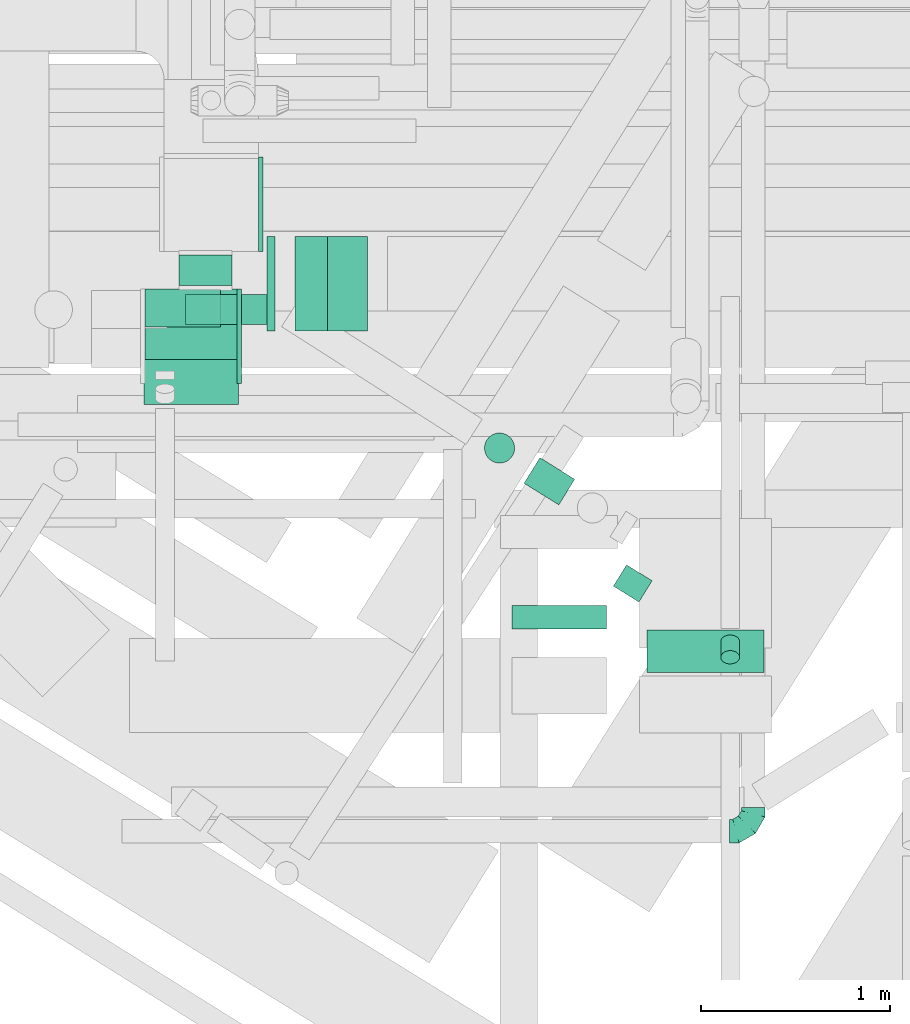
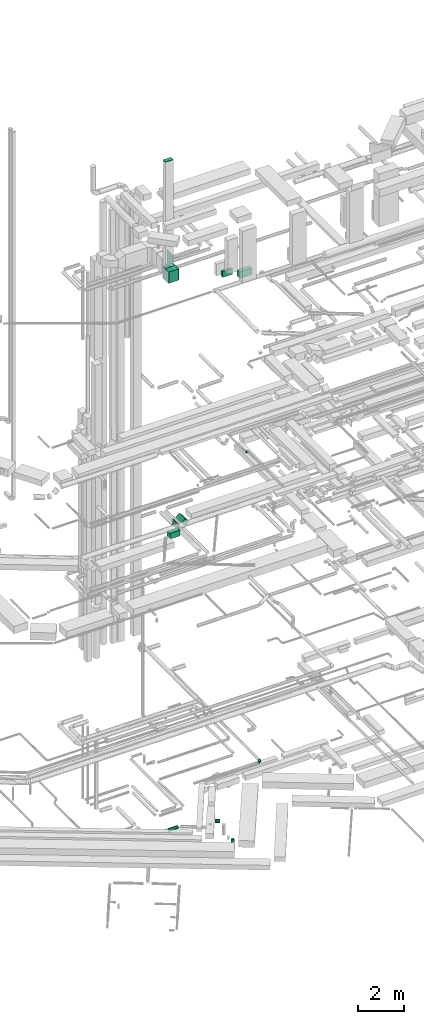
# One storey, part 95 of 337: 12 flow segments, 5 flow fittings.
"""IFC2X3 building model written with IfcOpenShell, lengths in millimetres."""

from ifc_helpers import new_model, entity, si_unit, converted_unit, derived_unit, direction, frame, frame_2d, origin, origin_2d_with_axis, place, context, subcontext, project, spatial, rectangle, circle, extrude, faceted_brep, source, transform, mapped, material, type_object, type_shapes, element, save


model = new_model("IFC2X3")

# Units and contexts
model_context = context("Model", 3, precision=0.01, world=origin(), true_north=direction((6.12303176911189e-17, 1.0)))
body_context = subcontext(model_context, "Body", "Model", "MODEL_VIEW")
ifc_project = project(units=[si_unit("LENGTHUNIT", "METRE", prefix="MILLI"), si_unit("AREAUNIT", "SQUARE_METRE"), si_unit("VOLUMEUNIT", "CUBIC_METRE"), converted_unit("PLANEANGLEUNIT", "DEGREE", entity("IfcRatioMeasure", 0.0174532925199433), si_unit("PLANEANGLEUNIT", "RADIAN"), dimensions=[0, 0, 0, 0, 0, 0, 0]), si_unit("MASSUNIT", "GRAM", prefix="KILO"), derived_unit("MASSDENSITYUNIT", [(si_unit("MASSUNIT", "GRAM", prefix="KILO"), 1), (si_unit("LENGTHUNIT", "METRE"), -3)]), derived_unit("MOMENTOFINERTIAUNIT", [(si_unit("LENGTHUNIT", "METRE"), 4)]), si_unit("TIMEUNIT", "SECOND"), si_unit("FREQUENCYUNIT", "HERTZ"), si_unit("THERMODYNAMICTEMPERATUREUNIT", "DEGREE_CELSIUS"), derived_unit("THERMALTRANSMITTANCEUNIT", [(si_unit("MASSUNIT", "GRAM", prefix="KILO"), 1), (si_unit("THERMODYNAMICTEMPERATUREUNIT", "KELVIN"), -1), (si_unit("TIMEUNIT", "SECOND"), -3)]), derived_unit("VOLUMETRICFLOWRATEUNIT", [(si_unit("LENGTHUNIT", "METRE"), 3), (si_unit("TIMEUNIT", "SECOND"), -1)]), derived_unit("MASSFLOWRATEUNIT", [(si_unit("MASSUNIT", "GRAM", prefix="KILO"), 1), (si_unit("TIMEUNIT", "SECOND"), -1)]), derived_unit("ROTATIONALFREQUENCYUNIT", [(si_unit("TIMEUNIT", "SECOND"), -1)]), si_unit("ELECTRICCURRENTUNIT", "AMPERE"), si_unit("ELECTRICVOLTAGEUNIT", "VOLT"), si_unit("POWERUNIT", "WATT"), si_unit("FORCEUNIT", "NEWTON", prefix="KILO"), si_unit("ILLUMINANCEUNIT", "LUX"), si_unit("LUMINOUSFLUXUNIT", "LUMEN"), si_unit("LUMINOUSINTENSITYUNIT", "CANDELA"), derived_unit("USERDEFINED", [(si_unit("MASSUNIT", "GRAM", prefix="KILO"), -1), (si_unit("LENGTHUNIT", "METRE"), -2), (si_unit("TIMEUNIT", "SECOND"), 3), (si_unit("LUMINOUSFLUXUNIT", "LUMEN"), 1)]), derived_unit("LINEARVELOCITYUNIT", [(si_unit("LENGTHUNIT", "METRE"), 1), (si_unit("TIMEUNIT", "SECOND"), -1)]), si_unit("PRESSUREUNIT", "PASCAL"), derived_unit("USERDEFINED", [(si_unit("LENGTHUNIT", "METRE"), -2), (si_unit("MASSUNIT", "GRAM", prefix="KILO"), 1), (si_unit("TIMEUNIT", "SECOND"), -2)]), derived_unit("LINEARFORCEUNIT", [(si_unit("MASSUNIT", "GRAM", prefix="KILO"), 1), (si_unit("LENGTHUNIT", "METRE"), 1), (si_unit("TIMEUNIT", "SECOND"), -2), (si_unit("LENGTHUNIT", "METRE"), -1)]), derived_unit("PLANARFORCEUNIT", [(si_unit("MASSUNIT", "GRAM", prefix="KILO"), 1), (si_unit("LENGTHUNIT", "METRE"), 1), (si_unit("TIMEUNIT", "SECOND"), -2), (si_unit("LENGTHUNIT", "METRE"), -2)])], contexts=[model_context])

# Site, building, storey
site_placement = place(None, origin())
site = spatial("IfcSite", under=ifc_project, at=site_placement, CompositionType="ELEMENT")
building_placement = place(site_placement, origin())
building = spatial("IfcBuilding", under=site, at=building_placement, CompositionType="ELEMENT")
storey_placement = place(building_placement, origin())
storey = spatial("IfcBuildingStorey", under=building, at=storey_placement, CompositionType="ELEMENT", Elevation=0.0)

# Flow segments
duct_segment_type_1 = type_object("IfcDuctSegmentType", PredefinedType="NOTDEFINED")
flow_segment_1_placement = place(storey_placement, frame((10668.17, 11089.53, 14800.0)))
element("IfcFlowSegment", 1, at=flow_segment_1_placement, inside=storey, type_object=duct_segment_type_1, context=body_context, shape_type="SweptSolid", body=[
    extrude(rectangle(XDim=42.7381929096469, YDim=499.999999999999, at=origin_2d_with_axis()), frame((21.37, 250.0, 0.0), z_axis=(0.0, 0.0, 1.0), x_axis=(-1.0, 0.0, 0.0)), (0.0, 0.0, 1.0), 300.000000000001),
])
flow_segment_2_placement = place(storey_placement, frame((10816.98, 11089.53, 14931.8)))
element("IfcFlowSegment", 2, at=flow_segment_2_placement, inside=storey, type_object=duct_segment_type_1, context=body_context, shape_type="SweptSolid", body=[
    extrude(rectangle(XDim=300.0, YDim=246.446605979802, at=frame_2d((0.0, 0.0), x_axis=(0.0, 1.0))), frame((193.2, 0.0, 193.2), z_axis=(0.0, 1.0, 0.0), x_axis=(0.707106781186552, 0.0, 0.707106781186543)), (0.0, 0.0, 1.0), 499.999999999999),
])
flow_segment_3_placement = place(storey_placement, frame((10018.17, 10699.62, 14800.0)))
element("IfcFlowSegment", 3, at=flow_segment_3_placement, inside=storey, type_object=duct_segment_type_1, context=body_context, shape_type="SweptSolid", body=[
    extrude(rectangle(XDim=239.911520284048, YDim=500.000000000001, at=origin_2d_with_axis()), frame((250.0, 119.96, 0.0), z_axis=(0.0, 0.0, 1.0), x_axis=(0.0, 1.0, 0.0)), (0.0, 0.0, 1.0), 300.000000000001),
])
flow_segment_4_placement = place(storey_placement, frame((10023.38, 10811.11, 28250.0)))
element("IfcFlowSegment", 4, at=flow_segment_4_placement, inside=storey, type_object=duct_segment_type_1, context=body_context, shape_type="SweptSolid", body=[
    extrude(rectangle(XDim=486.000000000002, YDim=500.000000000001, at=origin_2d_with_axis()), frame((243.0, 250.0, 0.0)), (0.0, 0.0, 1.0), 600.000000000002),
])
flow_segment_5_placement = place(storey_placement, frame((12682.68, 9279.6, 28512.0)))
element("IfcFlowSegment", 5, at=flow_segment_5_placement, inside=storey, type_object=duct_segment_type_1, context=body_context, shape_type="SweptSolid", body=[
    extrude(rectangle(XDim=224.720005594429, YDim=620.0, at=origin_2d_with_axis()), frame((310.0, 112.36, 0.0), z_axis=(0.0, 0.0, 1.0), x_axis=(0.0, -1.0, 0.0)), (0.0, 0.0, 1.0), 330.000000000003),
])
duct_segment_type_2 = type_object("IfcDuctSegmentType", PredefinedType="NOTDEFINED")
flow_segment_6_placement = place(storey_placement, frame((12030.41, 10166.26, -681.6)))
element("IfcFlowSegment", 6, at=flow_segment_6_placement, inside=storey, type_object=duct_segment_type_2, context=body_context, shape_type="SweptSolid", body=[
    extrude(circle(Radius=80.0, at=origin_2d_with_axis()), frame((227.92, 69.5, 81.6), z_axis=(-0.84880659771503, 0.528703470459042, 0.0), x_axis=(-0.528703470459042, -0.84880659771503, 0.0)), (0.0, 0.0, 1.0), 216.805694518982),
])
flow_segment_7_placement = place(storey_placement, frame((12503.94, 9651.04, -1534.4)))
element("IfcFlowSegment", 7, at=flow_segment_7_placement, inside=storey, type_object=duct_segment_type_2, context=body_context, shape_type="SweptSolid", body=[
    extrude(circle(Radius=80.0, at=origin_2d_with_axis()), frame((69.51, 43.88, 81.6), z_axis=(0.528543816030451, 0.848906022205031, 0.0), x_axis=(-0.848906022205031, 0.528543816030451, 0.0)), (0.0, 0.0, 1.0), 132.499999999991),
])
flow_segment_8_placement = place(storey_placement, frame((11820.63, 10387.43, -790.02)))
element("IfcFlowSegment", 8, at=flow_segment_8_placement, inside=storey, type_object=duct_segment_type_2, context=body_context, shape_type="SweptSolid", body=[
    extrude(circle(Radius=80.0, at=origin_2d_with_axis()), frame((81.52, 81.52, 0.02), z_axis=(0.000161501780461573, 0.000152885841720398, 0.999999975271547), x_axis=(-0.538261512874368, -0.842777845696967, 0.000215778998341716)), (0.0, 0.0, 1.0), 19.9742915699425),
])
flow_segment_9_placement = place(storey_placement, frame((10238.1, 11121.25, -1031.6)))
element("IfcFlowSegment", 9, at=flow_segment_9_placement, inside=storey, type_object=duct_segment_type_2, context=body_context, shape_type="SweptSolid", body=[
    extrude(circle(Radius=80.0, at=origin_2d_with_axis()), frame((0.0, 81.6, 81.6), z_axis=(1.0, 0.0, 0.0), x_axis=(0.0, 1.0, 0.0)), (0.0, 0.0, 1.0), 468.177455422959),
])
flow_segment_10_placement = place(storey_placement, frame((13073.16, 9322.95, 19042.34)))
element("IfcFlowSegment", 10, at=flow_segment_10_placement, inside=storey, type_object=duct_segment_type_2, context=body_context, shape_type="SweptSolid", body=[
    extrude(circle(Radius=50.0, at=origin_2d_with_axis()), frame((51.6, 36.95, 119.79), z_axis=(0.0, 0.707106781186548, -0.707106781186548), x_axis=(-1.0, 0.0, 0.0)), (0.0, 0.0, 1.0), 117.15728752539),
])
flow_segment_11_placement = place(storey_placement, frame((10202.05, 11331.11, 28421.66)))
element("IfcFlowSegment", 11, at=flow_segment_11_placement, inside=storey, type_object=duct_segment_type_2, context=body_context, shape_type="SweptSolid", body=[
    extrude(circle(Radius=140.0, at=origin_2d_with_axis()), frame((141.6, 0.0, 141.6), z_axis=(0.0, 1.0, 0.0), x_axis=(1.0, 0.0, 0.0)), (0.0, 0.0, 1.0), 159.999999999981),
])
duct_segment_type_3 = type_object("IfcDuctSegmentType", PredefinedType="NOTDEFINED")
flow_segment_12_placement = place(storey_placement, frame((11967.8, 9509.89, 28672.0)))
element("IfcFlowSegment", 12, at=flow_segment_12_placement, inside=storey, type_object=duct_segment_type_3, context=body_context, shape_type="SweptSolid", body=[
    extrude(rectangle(XDim=125.729113203038, YDim=499.999999999999, at=origin_2d_with_axis()), frame((250.0, 62.86, 0.0), z_axis=(0.0, 0.0, 1.0), x_axis=(0.0, -1.0, 0.0)), (0.0, 0.0, 1.0), 300.000000000001),
])

# Flow fittings
ifc_material = material()
duct_fitting_type_1 = type_object("IfcDuctFittingType", PredefinedType="NOTDEFINED", material=ifc_material)
shared_shape_1 = source(origin(), body_context, "Body", "SweptSolid", [
    extrude(rectangle(XDim=24.9999999999999, YDim=500.0, at=origin_2d_with_axis()), frame((12.5, 0.0, -400.0)), (0.0, 0.0, 1.0), 800.0),
])
type_shapes(duct_fitting_type_1, [shared_shape_1])
flow_fitting_1_placement = place(storey_placement, frame((10623.64, 11761.11, 28700.0)))
element("IfcFlowFitting", 13, at=flow_fitting_1_placement, inside=storey, type_object=duct_fitting_type_1, material=ifc_material, context=body_context, shape_type="MappedRepresentation", body=[
    mapped(shared_shape_1, transform((0.0, 0.0, 0.0), scale=1.0)),
])
duct_fitting_type_2 = type_object("IfcDuctFittingType", PredefinedType="NOTDEFINED", material=ifc_material)
shared_shape_2 = source(origin(), body_context, "Body", "SweptSolid", [
    extrude(rectangle(XDim=200.0, YDim=26.096, at=origin_2d_with_axis()), frame((6.95, 0.0, -200.0), z_axis=(0.0, 0.0, 1.0), x_axis=(0.0, -1.0, 0.0)), (0.0, 0.0, 1.0), 400.0),
])
type_shapes(duct_fitting_type_2, [shared_shape_2])
flow_fitting_2_placement = place(storey_placement, frame((10223.38, 11211.11, 28850.0), z_axis=(-1.0, 0.0, 0.0), x_axis=(0.0, 0.0, 1.0)))
element("IfcFlowFitting", 14, at=flow_fitting_2_placement, inside=storey, type_object=duct_fitting_type_2, material=ifc_material, context=body_context, shape_type="MappedRepresentation", body=[
    mapped(shared_shape_2, transform((0.0, 0.0, 0.0), scale=1.0)),
])
duct_fitting_type_3 = type_object("IfcDuctFittingType", PredefinedType="NOTDEFINED", material=ifc_material)
shared_shape_3 = source(origin(), body_context, "Body", "SweptSolid", [
    extrude(rectangle(XDim=24.9999999999999, YDim=500.0, at=origin_2d_with_axis()), frame((12.5, 0.0, -300.0)), (0.0, 0.0, 1.0), 600.0),
])
type_shapes(duct_fitting_type_3, [shared_shape_3])
flow_fitting_3_placement = place(storey_placement, frame((10509.38, 11061.11, 28550.0)))
element("IfcFlowFitting", 15, at=flow_fitting_3_placement, inside=storey, type_object=duct_fitting_type_3, material=ifc_material, context=body_context, shape_type="MappedRepresentation", body=[
    mapped(shared_shape_3, transform((0.0, 0.0, 0.0), scale=1.0)),
])
duct_fitting_type_4 = type_object("IfcDuctFittingType", PredefinedType="NOTDEFINED", material=ifc_material)
shared_shape_4 = source(origin(), body_context, "Body", "SweptSolid", [
    extrude(rectangle(XDim=24.9999999999999, YDim=200.0, at=origin_2d_with_axis()), frame((12.5, 0.0, -200.0)), (0.0, 0.0, 1.0), 400.0),
])
type_shapes(duct_fitting_type_4, [shared_shape_4])
flow_fitting_4_placement = place(storey_placement, frame((10223.38, 11211.11, 34460.0), z_axis=(-1.0, 0.0, 0.0), x_axis=(0.0, 0.0, 1.0)))
element("IfcFlowFitting", 16, at=flow_fitting_4_placement, inside=storey, type_object=duct_fitting_type_4, material=ifc_material, context=body_context, shape_type="MappedRepresentation", body=[
    mapped(shared_shape_4, transform((0.0, 0.0, 0.0), scale=1.0)),
])
duct_fitting_type_5 = type_object("IfcDuctFittingType", PredefinedType="NOTDEFINED", material=ifc_material)
shared_shape_5 = source(origin(), body_context, "Body", "Brep", [
    faceted_brep([(-125.0, 0.0, -62.5), (-125.0, -16.18, -60.37), (-125.0, -31.25, -54.13), (-125.0, -44.19, -44.19), (-125.0, -54.13, -31.25), (-125.0, -60.37, -16.18), (-125.0, -62.5, 0.0), (-125.0, -60.37, 16.18), (-125.0, -54.13, 31.25), (-125.0, -44.19, 44.19), (-125.0, -31.25, 54.13), (-125.0, -16.18, 60.37), (-125.0, 0.0, 62.5), (-125.0, 16.18, 60.37), (-125.0, 31.25, 54.13), (-125.0, 44.19, 44.19), (-125.0, 54.13, 31.25), (-125.0, 60.37, 16.18), (-125.0, 62.5, 0.0), (-125.0, 60.37, -16.18), (-125.0, 54.13, -31.25), (-125.0, 44.19, -44.19), (-125.0, 31.25, -54.13), (-125.0, 16.18, -60.37), (-95.84, 16.18, 60.37), (-99.88, 31.25, 54.13), (-91.51, 0.0, 62.5), (-103.35, 44.19, 44.19), (-107.68, 60.37, 16.18), (-108.25, 62.5, 0.0), (-106.01, 54.13, 31.25), (-106.01, 54.13, -31.25), (-103.35, 44.19, -44.19), (-107.68, 60.37, -16.18), (-95.84, 16.18, -60.37), (-91.51, 0.0, -62.5), (-99.88, 31.25, -54.13), (-87.17, -16.18, -60.37), (-83.13, -31.25, -54.13), (-79.66, -44.19, -44.19), (-77.0, -54.13, -31.25), (-75.33, -60.37, -16.18), (-74.76, -62.5, 0.0), (-75.33, -60.37, 16.18), (-77.0, -54.13, 31.25), (-79.66, -44.19, 44.19), (-83.13, -31.25, 54.13), (-87.17, -16.18, 60.37), (-45.34, 45.34, 60.37), (-56.37, 56.37, 54.13), (-33.49, 33.49, 62.5), (-65.85, 65.85, 44.19), (-73.12, 73.12, 31.25), (-77.69, 77.69, 16.18), (-79.25, 79.25, 0.0), (-77.69, 77.69, -16.18), (-73.12, 73.12, -31.25), (-65.85, 65.85, -44.19), (-45.34, 45.34, -60.37), (-33.49, 33.49, -62.5), (-56.37, 56.37, -54.13), (-21.65, 21.65, -60.37), (-10.62, 10.62, -54.13), (-1.14, 1.14, -44.19), (6.13, -6.13, -31.25), (10.7, -10.7, -16.18), (12.26, -12.26, 0.0), (10.7, -10.7, 16.18), (6.13, -6.13, 31.25), (-1.14, 1.14, 44.19), (-10.62, 10.62, 54.13), (-21.65, 21.65, 60.37), (-16.18, 95.84, 60.37), (-31.25, 99.88, 54.13), (0.0, 91.51, 62.5), (-44.19, 103.35, 44.19), (-54.13, 106.01, 31.25), (-60.37, 107.68, 16.18), (-62.5, 108.25, 0.0), (-60.37, 107.68, -16.18), (-54.13, 106.01, -31.25), (-44.19, 103.35, -44.19), (-16.18, 95.84, -60.37), (0.0, 91.51, -62.5), (-31.25, 99.88, -54.13), (16.18, 87.17, -60.37), (31.25, 83.13, -54.13), (44.19, 79.66, -44.19), (54.13, 77.0, -31.25), (60.37, 75.33, -16.18), (62.5, 74.76, 0.0), (60.37, 75.33, 16.18), (54.13, 77.0, 31.25), (44.19, 79.66, 44.19), (31.25, 83.13, 54.13), (16.18, 87.17, 60.37), (-16.18, 125.0, -60.37), (-31.25, 125.0, -54.13), (-44.19, 125.0, -44.19), (-54.13, 125.0, -31.25), (-60.37, 125.0, -16.18), (-62.5, 125.0, 0.0), (-60.37, 125.0, 16.18), (-54.13, 125.0, 31.25), (-44.19, 125.0, 44.19), (-31.25, 125.0, 54.13), (-16.18, 125.0, 60.37), (0.0, 125.0, 62.5), (16.18, 125.0, 60.37), (31.25, 125.0, 54.13), (44.19, 125.0, 44.19), (54.13, 125.0, 31.25), (60.37, 125.0, 16.18), (62.5, 125.0, 0.0), (60.37, 125.0, -16.18), (54.13, 125.0, -31.25), (44.19, 125.0, -44.19), (31.25, 125.0, -54.13), (16.18, 125.0, -60.37), (0.0, 125.0, -62.5)], [[[0, 1, 2, 3, 4, 5, 6, 7, 8, 9, 10, 11, 12, 13, 14, 15, 16, 17, 18, 19, 20, 21, 22, 23]], [[24, 25, 14, 13]], [[26, 24, 13, 12]], [[14, 25, 27, 15]], [[28, 29, 18, 17]], [[30, 28, 17, 16]], [[15, 27, 30, 16]], [[20, 31, 32, 21]], [[33, 31, 20, 19]], [[18, 29, 33, 19]], [[34, 35, 0, 23]], [[36, 34, 23, 22]], [[21, 32, 36, 22]], [[1, 0, 35, 37]], [[2, 1, 37, 38]], [[38, 39, 3, 2]], [[5, 4, 40, 41]], [[6, 5, 41, 42]], [[39, 40, 4, 3]], [[6, 42, 43, 7]], [[7, 43, 44, 8]], [[45, 9, 8, 44]], [[9, 45, 46, 10]], [[10, 46, 47, 11]], [[26, 12, 11, 47]], [[48, 49, 25, 24]], [[50, 48, 24, 26]], [[27, 25, 49, 51]], [[52, 53, 28, 30]], [[51, 52, 30, 27]], [[29, 28, 53, 54]], [[55, 56, 31, 33]], [[54, 55, 33, 29]], [[57, 32, 31, 56]], [[58, 59, 35, 34]], [[60, 58, 34, 36]], [[57, 60, 36, 32]], [[37, 35, 59, 61]], [[38, 37, 61, 62]], [[39, 38, 62, 63]], [[41, 40, 64, 65]], [[42, 41, 65, 66]], [[63, 64, 40, 39]], [[43, 42, 66, 67]], [[44, 43, 67, 68]], [[68, 69, 45, 44]], [[46, 45, 69, 70]], [[47, 46, 70, 71]], [[26, 47, 71, 50]], [[72, 73, 49, 48]], [[74, 72, 48, 50]], [[51, 49, 73, 75]], [[76, 77, 53, 52]], [[75, 76, 52, 51]], [[54, 53, 77, 78]], [[79, 80, 56, 55]], [[78, 79, 55, 54]], [[81, 57, 56, 80]], [[82, 83, 59, 58]], [[84, 82, 58, 60]], [[81, 84, 60, 57]], [[61, 59, 83, 85]], [[62, 61, 85, 86]], [[63, 62, 86, 87]], [[65, 64, 88, 89]], [[66, 65, 89, 90]], [[87, 88, 64, 63]], [[67, 66, 90, 91]], [[68, 67, 91, 92]], [[92, 93, 69, 68]], [[70, 69, 93, 94]], [[71, 70, 94, 95]], [[50, 71, 95, 74]], [[96, 97, 98, 99, 100, 101, 102, 103, 104, 105, 106, 107, 108, 109, 110, 111, 112, 113, 114, 115, 116, 117, 118, 119]], [[72, 74, 107, 106]], [[73, 72, 106, 105]], [[75, 73, 105, 104]], [[77, 76, 103, 102]], [[78, 77, 102, 101]], [[75, 104, 103, 76]], [[78, 101, 100, 79]], [[79, 100, 99, 80]], [[80, 99, 98, 81]], [[96, 119, 83, 82]], [[97, 96, 82, 84]], [[84, 81, 98, 97]], [[83, 119, 118, 85]], [[85, 118, 117, 86]], [[116, 87, 86, 117]], [[88, 115, 114, 89]], [[89, 114, 113, 90]], [[115, 88, 87, 116]], [[91, 90, 113, 112]], [[92, 91, 112, 111]], [[111, 110, 93, 92]], [[95, 94, 109, 108]], [[74, 95, 108, 107]], [[110, 109, 94, 93]]]),
])
type_shapes(duct_fitting_type_5, [shared_shape_5])
flow_fitting_5_placement = place(storey_placement, frame((13246.63, 8438.59, 3300.0)))
element("IfcFlowFitting", 17, at=flow_fitting_5_placement, inside=storey, type_object=duct_fitting_type_5, material=ifc_material, context=body_context, shape_type="MappedRepresentation", body=[
    mapped(shared_shape_5, transform((0.0, 0.0, 0.0), scale=1.0)),
])

save(model, "model.ifc")
